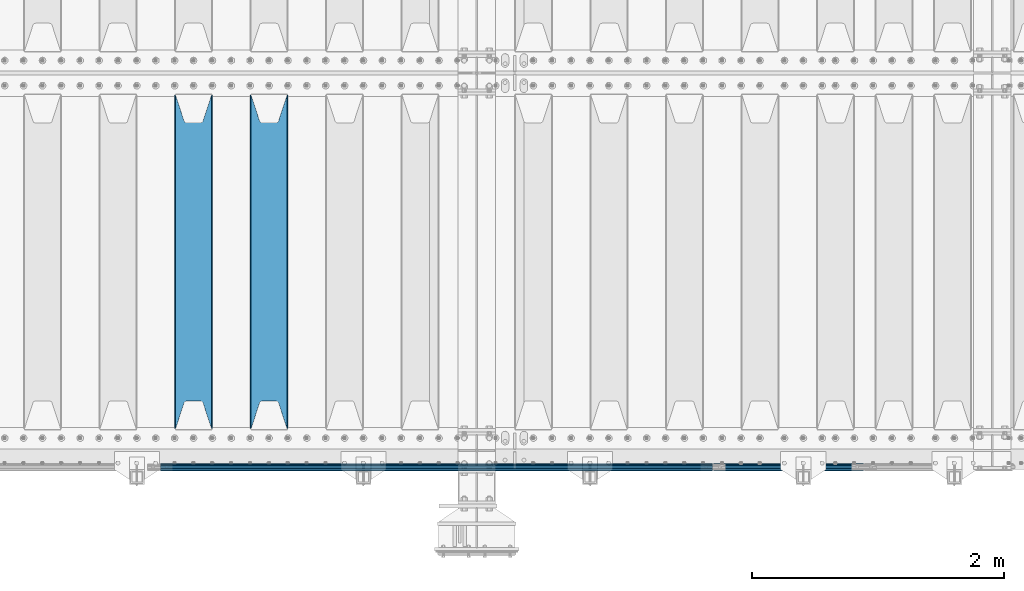
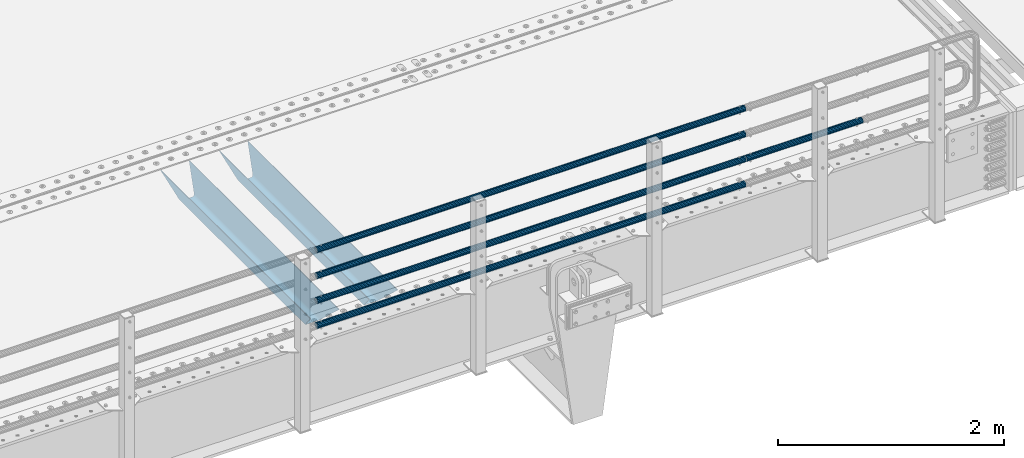
# One storey, part 114 of 247: 7 beams.
"""IFC2X3 building model written with IfcOpenShell, lengths in millimetres."""

from ifc_helpers import new_model, si_unit, frame, origin_with_axes, place, context, subcontext, project, spatial, faceted_brep, material, type_object, element, save


model = new_model("IFC2X3")

# Units and contexts
model_context = context("Model", 3, precision=1e-05, world=origin_with_axes())
body_context = subcontext(model_context, "Body", "Model", "MODEL_VIEW")
ifc_project = project(units=[si_unit("LENGTHUNIT", "METRE", prefix="MILLI"), si_unit("AREAUNIT", "SQUARE_METRE"), si_unit("VOLUMEUNIT", "CUBIC_METRE"), si_unit("MASSUNIT", "GRAM", prefix="KILO"), si_unit("TIMEUNIT", "SECOND"), si_unit("PLANEANGLEUNIT", "RADIAN"), si_unit("SOLIDANGLEUNIT", "STERADIAN"), si_unit("THERMODYNAMICTEMPERATUREUNIT", "DEGREE_CELSIUS"), si_unit("LUMINOUSINTENSITYUNIT", "LUMEN")], contexts=[model_context])

# Site, building, storey
site_placement = place(None, origin_with_axes())
site = spatial("IfcSite", under=ifc_project, at=site_placement, CompositionType="ELEMENT")
building_placement = place(site_placement, origin_with_axes())
building = spatial("IfcBuilding", under=site, at=building_placement, Name="Standard", CompositionType="ELEMENT")
storey_placement = place(building_placement, origin_with_axes())
storey = spatial("IfcBuildingStorey", under=building, at=storey_placement, Name="Undefined", CompositionType="ELEMENT", Elevation=0.0)

# Beams
ifc_material_1 = material(Name="STEEL/S355N")
beam_type_1 = type_object("IfcBeamType", PredefinedType="NOTDEFINED")
beam_1_placement = place(storey_placement, frame((10600.0, 175.0, -115.0), z_axis=(0.0, 0.0, 1.0), x_axis=(0.0, 1.0, 0.0)))
element("IfcBeam", 1, at=beam_1_placement, inside=storey, type_object=beam_type_1, material=ifc_material_1, context=body_context, shape_type="Brep", body=[
    faceted_brep([(0.0, 150.0, 115.0), (0.0, 143.689999999999, 115.0), (2650.00000000297, 143.689999999999, 115.0), (2650.00000000297, 150.0, 115.0), (2650.00000000297, 142.059565218402, 110.0000000031), (2650.00000000297, 148.369565218403, 110.0000000031), (2441.90079219208, -80.1103600731112, -98.0992078077845), (2437.7588105432, -77.5672621345584, -102.241189456673), (2434.06523489746, -74.4080125315522, -105.934765102404), (2430.91086095089, -70.710272125576, -109.089139048974), (2428.37322971128, -66.5649389910068, -111.626770288588), (2426.51472138054, -62.0739139532889, -113.485278619323), (2425.38102192091, -57.3475956567672, -114.618978078955), (2424.99999999987, -52.5021667386536, -115.0), (2424.99999999987, 52.5021667386536, -115.0), (2425.38102192091, 57.3475956567672, -114.618978078955), (2426.51472138054, 62.0739139532889, -113.485278619323), (2428.37322971128, 66.5649389910068, -111.626770288588), (2430.91086095089, 70.710272125576, -109.089139048974), (2434.06523489746, 74.4080125315522, -105.934765102404), (2437.7588105432, 77.5672621345584, -102.241189456673), (2441.90079219208, 80.1103600731112, -98.0992078077846), (2446.38936140511, 81.9747917625791, -93.6106385947584), (2448.24948500409, 76.2713538057251, -91.7505149957729), (2444.62967112262, 74.76777986261, -95.3703288772456), (2441.28936334126, 72.7168944282894, -98.710636658607), (2438.31067330438, 70.1691124903846, -101.689326695487), (2435.76682334747, 67.1870637758839, -104.233176652398), (2433.72034654133, 63.8440531834895, -106.279653458539), (2432.22154950041, 60.222258798236, -107.778450499454), (2431.30727574265, 56.4107117849089, -108.692724257221), (2430.99999999987, 52.5031078186876, -109.0), (2430.99999999987, -52.5031078186876, -109.0), (2431.30727574265, -56.4107117849089, -108.692724257221), (2432.22154950041, -60.222258798236, -107.778450499454), (2433.72034654133, -63.8440531834895, -106.279653458539), (2435.76682334747, -67.1870637758839, -104.233176652398), (2438.31067330438, -70.1691124903846, -101.689326695487), (2441.28936334126, -72.7168944282894, -98.7106366586071), (2444.62967112262, -74.76777986261, -95.3703288772457), (2448.24948500409, -76.2713538057251, -91.7505149957729), (2650.00000000297, -142.059565218402, 110.0000000031), (2650.00000000297, -148.369565218403, 110.0000000031), (2446.38936140511, -81.9747917625791, -93.6106385947584), (2650.00000000297, -143.689999999999, 115.0), (2650.00000000297, -150.0, 115.0), (0.0, -143.689999999999, 115.0), (0.0, -150.0, 115.0), (0.0, -148.369565218261, 110.000000002663), (203.610638597422, -81.9747917625791, -93.6106385947584), (208.099207810448, -80.1103600731112, -98.0992078077845), (212.241189459336, -77.5672621345584, -102.241189456673), (215.934765105068, -74.4080125315522, -105.934765102404), (219.089139051637, -70.710272125576, -109.089139048974), (221.626770291251, -66.5649389910068, -111.626770288588), (223.485278621985, -62.0739139532889, -113.485278619323), (224.618978081617, -57.3475956567672, -114.618978078955), (225.000000002663, -52.5021667386536, -115.0), (225.000000002663, 52.5021667386536, -115.0), (224.618978081617, 57.3475956567672, -114.618978078955), (223.485278621985, 62.0739139532889, -113.485278619323), (221.626770291251, 66.5649389910068, -111.626770288588), (219.089139051637, 70.710272125576, -109.089139048974), (215.934765105068, 74.4080125315522, -105.934765102404), (212.241189459336, 77.5672621345584, -102.241189456673), (208.099207810448, 80.1103600731112, -98.0992078077846), (203.610638597422, 81.9747917625791, -93.6106385947584), (0.0, 148.369565218261, 110.000000002663), (0.0, 142.05956521826, 110.000000002663), (201.750514998436, 76.2713538057251, -91.7505149957729), (205.370328879908, 74.76777986261, -95.3703288772456), (208.710636661271, 72.7168944282894, -98.710636658607), (211.68932669815, 70.1691124903846, -101.689326695487), (214.233176655061, 67.1870637758839, -104.233176652398), (216.279653461202, 63.8440531834895, -106.279653458539), (217.778450502117, 60.222258798236, -107.778450499454), (218.692724259885, 56.4107117849089, -108.692724257221), (219.000000002663, 52.5031078186876, -109.0), (219.000000002663, -52.5031078186876, -109.0), (218.692724259885, -56.4107117849089, -108.692724257221), (217.778450502117, -60.222258798236, -107.778450499454), (216.279653461202, -63.8440531834895, -106.279653458539), (214.233176655061, -67.1870637758839, -104.233176652398), (211.68932669815, -70.1691124903846, -101.689326695487), (208.710636661271, -72.7168944282894, -98.7106366586071), (205.370328879908, -74.76777986261, -95.3703288772457), (201.750514998436, -76.2713538057251, -91.7505149957729), (0.0, -142.05956521826, 110.000000002663)], [[[0, 1, 2, 3]], [[3, 2, 4, 5]], [[6, 7, 8, 9, 10, 11, 12, 13, 14, 15, 16, 17, 18, 19, 20, 21, 22, 5, 4, 23, 24, 25, 26, 27, 28, 29, 30, 31, 32, 33, 34, 35, 36, 37, 38, 39, 40, 41, 42, 43]], [[44, 45, 42, 41]], [[46, 47, 45, 44]], [[43, 42, 45, 47, 48, 49]], [[6, 43, 49, 50]], [[7, 6, 50, 51]], [[8, 7, 51, 52]], [[9, 8, 52, 53]], [[10, 9, 53, 54]], [[11, 10, 54, 55]], [[12, 11, 55, 56]], [[13, 12, 56, 57]], [[14, 13, 57, 58]], [[15, 14, 58, 59]], [[16, 15, 59, 60]], [[17, 16, 60, 61]], [[18, 17, 61, 62]], [[19, 18, 62, 63]], [[20, 19, 63, 64]], [[21, 20, 64, 65]], [[22, 21, 65, 66]], [[0, 3, 5, 22, 66, 67]], [[1, 0, 67, 68]], [[23, 4, 2, 1, 68, 69]], [[24, 23, 69, 70]], [[25, 24, 70, 71]], [[26, 25, 71, 72]], [[27, 26, 72, 73]], [[28, 27, 73, 74]], [[29, 28, 74, 75]], [[30, 29, 75, 76]], [[31, 30, 76, 77]], [[32, 31, 77, 78]], [[33, 32, 78, 79]], [[34, 33, 79, 80]], [[35, 34, 80, 81]], [[36, 35, 81, 82]], [[37, 36, 82, 83]], [[38, 37, 83, 84]], [[39, 38, 84, 85]], [[40, 39, 85, 86]], [[46, 44, 41, 40, 86, 87]], [[47, 46, 87, 48]], [[86, 85, 84, 83, 82, 81, 80, 79, 78, 77, 76, 75, 74, 73, 72, 71, 70, 69, 68, 67, 66, 65, 64, 63, 62, 61, 60, 59, 58, 57, 56, 55, 54, 53, 52, 51, 50, 49, 48, 87]]]),
])
beam_2_placement = place(storey_placement, frame((10000.0, 175.0, -115.0), z_axis=(0.0, 0.0, 1.0), x_axis=(0.0, 1.0, 0.0)))
element("IfcBeam", 2, at=beam_2_placement, inside=storey, type_object=beam_type_1, material=ifc_material_1, context=body_context, shape_type="Brep", body=[
    faceted_brep([(0.0, 150.0, 115.0), (0.0, 143.689999999999, 115.0), (2650.00000000297, 143.689999999999, 115.0), (2650.00000000297, 150.0, 115.0), (2650.00000000297, 142.059565218402, 110.0000000031), (2650.00000000297, 148.369565218403, 110.0000000031), (2441.90079219208, -80.1103600731112, -98.0992078077845), (2437.7588105432, -77.5672621345584, -102.241189456673), (2434.06523489746, -74.4080125315522, -105.934765102404), (2430.91086095089, -70.710272125576, -109.089139048974), (2428.37322971128, -66.5649389910068, -111.626770288588), (2426.51472138054, -62.0739139532889, -113.485278619323), (2425.38102192091, -57.3475956567672, -114.618978078955), (2424.99999999987, -52.5021667386536, -115.0), (2424.99999999987, 52.5021667386536, -115.0), (2425.38102192091, 57.3475956567672, -114.618978078955), (2426.51472138054, 62.0739139532889, -113.485278619323), (2428.37322971128, 66.5649389910068, -111.626770288588), (2430.91086095089, 70.710272125576, -109.089139048974), (2434.06523489746, 74.4080125315522, -105.934765102404), (2437.7588105432, 77.5672621345584, -102.241189456673), (2441.90079219208, 80.1103600731112, -98.0992078077846), (2446.38936140511, 81.9747917625791, -93.6106385947584), (2448.24948500409, 76.2713538057251, -91.7505149957729), (2444.62967112262, 74.76777986261, -95.3703288772456), (2441.28936334126, 72.7168944282894, -98.710636658607), (2438.31067330438, 70.1691124903846, -101.689326695487), (2435.76682334747, 67.1870637758839, -104.233176652398), (2433.72034654133, 63.8440531834895, -106.279653458539), (2432.22154950041, 60.222258798236, -107.778450499454), (2431.30727574265, 56.4107117849089, -108.692724257221), (2430.99999999987, 52.5031078186876, -109.0), (2430.99999999987, -52.5031078186876, -109.0), (2431.30727574265, -56.4107117849089, -108.692724257221), (2432.22154950041, -60.222258798236, -107.778450499454), (2433.72034654133, -63.8440531834895, -106.279653458539), (2435.76682334747, -67.1870637758839, -104.233176652398), (2438.31067330438, -70.1691124903846, -101.689326695487), (2441.28936334126, -72.7168944282894, -98.7106366586071), (2444.62967112262, -74.76777986261, -95.3703288772457), (2448.24948500409, -76.2713538057251, -91.7505149957729), (2650.00000000297, -142.059565218402, 110.0000000031), (2650.00000000297, -148.369565218403, 110.0000000031), (2446.38936140511, -81.9747917625791, -93.6106385947584), (2650.00000000297, -143.689999999999, 115.0), (2650.00000000297, -150.0, 115.0), (0.0, -143.689999999999, 115.0), (0.0, -150.0, 115.0), (0.0, -148.369565218261, 110.000000002663), (203.610638597422, -81.9747917625791, -93.6106385947584), (208.099207810448, -80.1103600731112, -98.0992078077845), (212.241189459336, -77.5672621345584, -102.241189456673), (215.934765105068, -74.4080125315522, -105.934765102404), (219.089139051637, -70.710272125576, -109.089139048974), (221.626770291251, -66.5649389910068, -111.626770288588), (223.485278621985, -62.0739139532889, -113.485278619323), (224.618978081617, -57.3475956567672, -114.618978078955), (225.000000002663, -52.5021667386536, -115.0), (225.000000002663, 52.5021667386536, -115.0), (224.618978081617, 57.3475956567672, -114.618978078955), (223.485278621985, 62.0739139532889, -113.485278619323), (221.626770291251, 66.5649389910068, -111.626770288588), (219.089139051637, 70.710272125576, -109.089139048974), (215.934765105068, 74.4080125315522, -105.934765102404), (212.241189459336, 77.5672621345584, -102.241189456673), (208.099207810448, 80.1103600731112, -98.0992078077846), (203.610638597422, 81.9747917625791, -93.6106385947584), (0.0, 148.369565218261, 110.000000002663), (0.0, 142.05956521826, 110.000000002663), (201.750514998436, 76.2713538057251, -91.7505149957729), (205.370328879908, 74.76777986261, -95.3703288772456), (208.710636661271, 72.7168944282894, -98.710636658607), (211.68932669815, 70.1691124903846, -101.689326695487), (214.233176655061, 67.1870637758839, -104.233176652398), (216.279653461202, 63.8440531834895, -106.279653458539), (217.778450502117, 60.222258798236, -107.778450499454), (218.692724259885, 56.4107117849089, -108.692724257221), (219.000000002663, 52.5031078186876, -109.0), (219.000000002663, -52.5031078186876, -109.0), (218.692724259885, -56.4107117849089, -108.692724257221), (217.778450502117, -60.222258798236, -107.778450499454), (216.279653461202, -63.8440531834895, -106.279653458539), (214.233176655061, -67.1870637758839, -104.233176652398), (211.68932669815, -70.1691124903846, -101.689326695487), (208.710636661271, -72.7168944282894, -98.7106366586071), (205.370328879908, -74.76777986261, -95.3703288772457), (201.750514998436, -76.2713538057251, -91.7505149957729), (0.0, -142.05956521826, 110.000000002663)], [[[0, 1, 2, 3]], [[3, 2, 4, 5]], [[6, 7, 8, 9, 10, 11, 12, 13, 14, 15, 16, 17, 18, 19, 20, 21, 22, 5, 4, 23, 24, 25, 26, 27, 28, 29, 30, 31, 32, 33, 34, 35, 36, 37, 38, 39, 40, 41, 42, 43]], [[44, 45, 42, 41]], [[46, 47, 45, 44]], [[43, 42, 45, 47, 48, 49]], [[6, 43, 49, 50]], [[7, 6, 50, 51]], [[8, 7, 51, 52]], [[9, 8, 52, 53]], [[10, 9, 53, 54]], [[11, 10, 54, 55]], [[12, 11, 55, 56]], [[13, 12, 56, 57]], [[14, 13, 57, 58]], [[15, 14, 58, 59]], [[16, 15, 59, 60]], [[17, 16, 60, 61]], [[18, 17, 61, 62]], [[19, 18, 62, 63]], [[20, 19, 63, 64]], [[21, 20, 64, 65]], [[22, 21, 65, 66]], [[0, 3, 5, 22, 66, 67]], [[1, 0, 67, 68]], [[23, 4, 2, 1, 68, 69]], [[24, 23, 69, 70]], [[25, 24, 70, 71]], [[26, 25, 71, 72]], [[27, 26, 72, 73]], [[28, 27, 73, 74]], [[29, 28, 74, 75]], [[30, 29, 75, 76]], [[31, 30, 76, 77]], [[32, 31, 77, 78]], [[33, 32, 78, 79]], [[34, 33, 79, 80]], [[35, 34, 80, 81]], [[36, 35, 81, 82]], [[37, 36, 82, 83]], [[38, 37, 83, 84]], [[39, 38, 84, 85]], [[40, 39, 85, 86]], [[46, 44, 41, 40, 86, 87]], [[47, 46, 87, 48]], [[86, 85, 84, 83, 82, 81, 80, 79, 78, 77, 76, 75, 74, 73, 72, 71, 70, 69, 68, 67, 66, 65, 64, 63, 62, 61, 60, 59, 58, 57, 56, 55, 54, 53, 52, 51, 50, 49, 48, 87]]]),
])
ifc_material_2 = material()
beam_type_2 = type_object("IfcBeamType", PredefinedType="NOTDEFINED")
beam_3_placement = place(storey_placement, frame((14121.9999999999, -129.849999999805, 149.849999999725), z_axis=(0.0, 0.0, -1.0), x_axis=(-1.0, 0.0, 0.0)))
element("IfcBeam", 3, at=beam_3_placement, inside=storey, type_object=beam_type_2, material=ifc_material_2, context=body_context, shape_type="Brep", body=[
    faceted_brep([(0.0, -26.5499999999993, 0.0), (0.0, -24.5290015881747, 10.1602451292931), (4384.0, -24.5290015881747, 10.1602451292931), (4384.0, -26.5499999999993, 0.0), (0.0, -18.7736850405036, 18.7736850405028), (4384.0, -18.7736850405036, 18.7736850405028), (0.0, -10.1602451292929, 24.5290015881747), (4384.0, -10.1602451292929, 24.5290015881747), (0.0, 0.0, 26.55), (4384.0, 0.0, 26.55), (0.0, 10.1602451292929, 24.5290015881747), (4384.0, 10.1602451292929, 24.5290015881747), (0.0, 18.7736850405036, 18.7736850405028), (4384.0, 18.7736850405036, 18.7736850405028), (0.0, 24.5290015881747, 10.1602451292931), (4384.0, 24.5290015881747, 10.1602451292931), (0.0, 26.5499999999993, 0.0), (4384.0, 26.5499999999993, 0.0), (0.0, 24.5290015881747, -10.1602451292931), (4384.0, 24.5290015881747, -10.1602451292931), (0.0, 18.7736850405036, -18.7736850405028), (4384.0, 18.7736850405036, -18.7736850405028), (0.0, 10.1602451292929, -24.5290015881747), (4384.0, 10.1602451292929, -24.5290015881747), (0.0, 0.0, -26.55), (4384.0, 0.0, -26.55), (0.0, -10.1602451292929, -24.5290015881747), (4384.0, -10.1602451292929, -24.5290015881747), (0.0, -18.7736850405036, -18.7736850405028), (4384.0, -18.7736850405036, -18.7736850405028), (0.0, -24.5290015881747, -10.1602451292931), (4384.0, -24.5290015881747, -10.1602451292931), (0.0, -30.1499999999996, 0.0), (0.0, -27.8549679052148, -11.5379054858076), (4384.0, -27.8549679052157, -11.5379054858075), (4384.0, -30.1499999999996, 0.0), (0.0, -21.3192694527743, -21.3192694527752), (4384.0, -21.3192694527752, -21.3192694527744), (0.0, -11.5379054858076, -27.8549679052157), (4384.0, -11.5379054858076, -27.8549679052153), (0.0, 0.0, -30.1499999999996), (4384.0, 0.0, -30.15), (0.0, 11.5379054858076, -27.8549679052157), (4384.0, 11.5379054858076, -27.8549679052153), (0.0, 21.3192694527743, -21.3192694527752), (4384.0, 21.3192694527752, -21.3192694527744), (0.0, 27.8549679052157, -11.5379054858076), (4384.0, 27.8549679052157, -11.5379054858074), (0.0, 30.1499999999996, 0.0), (4384.0, 30.1499999999996, 0.0), (0.0, 27.8549679052157, 11.5379054858076), (4384.0, 27.8549679052157, 11.5379054858075), (0.0, 21.3192694527743, 21.3192694527752), (4384.0, 21.3192694527752, 21.3192694527744), (0.0, 11.5379054858076, 27.8549679052157), (4384.0, 11.5379054858076, 27.8549679052153), (0.0, 0.0, 30.1499999999996), (4384.0, 0.0, 30.15), (0.0, -11.5379054858076, 27.8549679052157), (4384.0, -11.5379054858076, 27.8549679052153), (0.0, -21.3192694527743, 21.3192694527752), (4384.0, -21.3192694527752, 21.3192694527744), (0.0, -27.8549679052157, 11.5379054858076), (4384.0, -27.8549679052157, 11.5379054858075)], [[[0, 1, 2, 3]], [[1, 4, 5, 2]], [[4, 6, 7, 5]], [[6, 8, 9, 7]], [[8, 10, 11, 9]], [[10, 12, 13, 11]], [[12, 14, 15, 13]], [[14, 16, 17, 15]], [[16, 18, 19, 17]], [[18, 20, 21, 19]], [[20, 22, 23, 21]], [[22, 24, 25, 23]], [[24, 26, 27, 25]], [[26, 28, 29, 27]], [[28, 30, 31, 29]], [[30, 0, 3, 31]], [[32, 33, 34, 35]], [[33, 36, 37, 34]], [[36, 38, 39, 37]], [[38, 40, 41, 39]], [[40, 42, 43, 41]], [[42, 44, 45, 43]], [[44, 46, 47, 45]], [[46, 48, 49, 47]], [[48, 50, 51, 49]], [[50, 52, 53, 51]], [[52, 54, 55, 53]], [[54, 56, 57, 55]], [[56, 58, 59, 57]], [[58, 60, 61, 59]], [[60, 62, 63, 61]], [[62, 32, 35, 63]], [[37, 39, 41, 43, 45, 47, 49, 51, 53, 55, 57, 59, 61, 63, 35, 34], [5, 7, 9, 11, 13, 15, 17, 19, 21, 23, 25, 27, 29, 31, 3, 2]], [[62, 60, 58, 56, 54, 52, 50, 48, 46, 44, 42, 40, 38, 36, 33, 32], [30, 28, 26, 24, 22, 20, 18, 16, 14, 12, 10, 8, 6, 4, 1, 0]]]),
])
beam_4_placement = place(storey_placement, frame((14121.9999999999, -129.849999999805, 420.149999999728), z_axis=(0.0, 0.0, -1.0), x_axis=(-1.0, 0.0, 0.0)))
element("IfcBeam", 4, at=beam_4_placement, inside=storey, type_object=beam_type_2, material=ifc_material_2, context=body_context, shape_type="Brep", body=[
    faceted_brep([(0.0, -26.5499999999993, 0.0), (0.0, -24.5290015881747, 10.1602451292931), (4384.0, -24.5290015881747, 10.1602451292931), (4384.0, -26.5499999999993, 0.0), (0.0, -18.7736850405036, 18.7736850405028), (4384.0, -18.7736850405036, 18.7736850405028), (0.0, -10.1602451292929, 24.5290015881747), (4384.0, -10.1602451292929, 24.5290015881747), (0.0, 0.0, 26.55), (4384.0, 0.0, 26.55), (0.0, 10.1602451292929, 24.5290015881747), (4384.0, 10.1602451292929, 24.5290015881747), (0.0, 18.7736850405036, 18.7736850405028), (4384.0, 18.7736850405036, 18.7736850405028), (0.0, 24.5290015881747, 10.1602451292931), (4384.0, 24.5290015881747, 10.1602451292931), (0.0, 26.5499999999993, 0.0), (4384.0, 26.5499999999993, 0.0), (0.0, 24.5290015881747, -10.1602451292931), (4384.0, 24.5290015881747, -10.1602451292931), (0.0, 18.7736850405036, -18.7736850405028), (4384.0, 18.7736850405036, -18.7736850405028), (0.0, 10.1602451292929, -24.5290015881747), (4384.0, 10.1602451292929, -24.5290015881747), (0.0, 0.0, -26.55), (4384.0, 0.0, -26.55), (0.0, -10.1602451292929, -24.5290015881747), (4384.0, -10.1602451292929, -24.5290015881747), (0.0, -18.7736850405036, -18.7736850405028), (4384.0, -18.7736850405036, -18.7736850405028), (0.0, -24.5290015881747, -10.1602451292931), (4384.0, -24.5290015881747, -10.1602451292931), (0.0, -30.1499999999996, 0.0), (0.0, -27.8549679052148, -11.5379054858076), (4384.0, -27.8549679052157, -11.5379054858075), (4384.0, -30.1499999999996, 0.0), (0.0, -21.3192694527743, -21.3192694527752), (4384.0, -21.3192694527752, -21.3192694527744), (0.0, -11.5379054858076, -27.8549679052157), (4384.0, -11.5379054858076, -27.8549679052153), (0.0, 0.0, -30.1499999999996), (4384.0, 0.0, -30.15), (0.0, 11.5379054858076, -27.8549679052157), (4384.0, 11.5379054858076, -27.8549679052153), (0.0, 21.3192694527743, -21.3192694527752), (4384.0, 21.3192694527752, -21.3192694527744), (0.0, 27.8549679052157, -11.5379054858076), (4384.0, 27.8549679052157, -11.5379054858074), (0.0, 30.1499999999996, 0.0), (4384.0, 30.1499999999996, 0.0), (0.0, 27.8549679052157, 11.5379054858076), (4384.0, 27.8549679052157, 11.5379054858075), (0.0, 21.3192694527743, 21.3192694527752), (4384.0, 21.3192694527752, 21.3192694527744), (0.0, 11.5379054858076, 27.8549679052157), (4384.0, 11.5379054858076, 27.8549679052153), (0.0, 0.0, 30.1499999999996), (4384.0, 0.0, 30.15), (0.0, -11.5379054858076, 27.8549679052157), (4384.0, -11.5379054858076, 27.8549679052153), (0.0, -21.3192694527743, 21.3192694527752), (4384.0, -21.3192694527752, 21.3192694527744), (0.0, -27.8549679052157, 11.5379054858076), (4384.0, -27.8549679052157, 11.5379054858075)], [[[0, 1, 2, 3]], [[1, 4, 5, 2]], [[4, 6, 7, 5]], [[6, 8, 9, 7]], [[8, 10, 11, 9]], [[10, 12, 13, 11]], [[12, 14, 15, 13]], [[14, 16, 17, 15]], [[16, 18, 19, 17]], [[18, 20, 21, 19]], [[20, 22, 23, 21]], [[22, 24, 25, 23]], [[24, 26, 27, 25]], [[26, 28, 29, 27]], [[28, 30, 31, 29]], [[30, 0, 3, 31]], [[32, 33, 34, 35]], [[33, 36, 37, 34]], [[36, 38, 39, 37]], [[38, 40, 41, 39]], [[40, 42, 43, 41]], [[42, 44, 45, 43]], [[44, 46, 47, 45]], [[46, 48, 49, 47]], [[48, 50, 51, 49]], [[50, 52, 53, 51]], [[52, 54, 55, 53]], [[54, 56, 57, 55]], [[56, 58, 59, 57]], [[58, 60, 61, 59]], [[60, 62, 63, 61]], [[62, 32, 35, 63]], [[37, 39, 41, 43, 45, 47, 49, 51, 53, 55, 57, 59, 61, 63, 35, 34], [5, 7, 9, 11, 13, 15, 17, 19, 21, 23, 25, 27, 29, 31, 3, 2]], [[62, 60, 58, 56, 54, 52, 50, 48, 46, 44, 42, 40, 38, 36, 33, 32], [30, 28, 26, 24, 22, 20, 18, 16, 14, 12, 10, 8, 6, 4, 1, 0]]]),
])
beam_5_placement = place(storey_placement, frame((14121.9999999999, -129.849999999805, 969.849999999725), z_axis=(0.0, 0.0, -1.0), x_axis=(-1.0, 0.0, 0.0)))
element("IfcBeam", 5, at=beam_5_placement, inside=storey, type_object=beam_type_2, material=ifc_material_2, context=body_context, shape_type="Brep", body=[
    faceted_brep([(0.0, -26.5499999999993, 0.0), (0.0, -24.5290015881747, 10.1602451292931), (4384.0, -24.5290015881747, 10.1602451292931), (4384.0, -26.5499999999993, 0.0), (0.0, -18.7736850405036, 18.7736850405028), (4384.0, -18.7736850405036, 18.7736850405028), (0.0, -10.1602451292929, 24.5290015881747), (4384.0, -10.1602451292929, 24.5290015881747), (0.0, 0.0, 26.55), (4384.0, 0.0, 26.55), (0.0, 10.1602451292929, 24.5290015881747), (4384.0, 10.1602451292929, 24.5290015881747), (0.0, 18.7736850405036, 18.7736850405028), (4384.0, 18.7736850405036, 18.7736850405028), (0.0, 24.5290015881747, 10.1602451292931), (4384.0, 24.5290015881747, 10.1602451292931), (0.0, 26.5499999999993, 0.0), (4384.0, 26.5499999999993, 0.0), (0.0, 24.5290015881747, -10.1602451292931), (4384.0, 24.5290015881747, -10.1602451292931), (0.0, 18.7736850405036, -18.7736850405028), (4384.0, 18.7736850405036, -18.7736850405028), (0.0, 10.1602451292929, -24.5290015881747), (4384.0, 10.1602451292929, -24.5290015881747), (0.0, 0.0, -26.55), (4384.0, 0.0, -26.55), (0.0, -10.1602451292929, -24.5290015881747), (4384.0, -10.1602451292929, -24.5290015881747), (0.0, -18.7736850405036, -18.7736850405028), (4384.0, -18.7736850405036, -18.7736850405028), (0.0, -24.5290015881747, -10.1602451292931), (4384.0, -24.5290015881747, -10.1602451292931), (0.0, -30.1499999999996, 0.0), (0.0, -27.8549679052148, -11.5379054858076), (4384.0, -27.8549679052157, -11.5379054858075), (4384.0, -30.1499999999996, 0.0), (0.0, -21.3192694527743, -21.3192694527752), (4384.0, -21.3192694527752, -21.3192694527744), (0.0, -11.5379054858076, -27.8549679052157), (4384.0, -11.5379054858076, -27.8549679052153), (0.0, 0.0, -30.1499999999996), (4384.0, 0.0, -30.15), (0.0, 11.5379054858076, -27.8549679052157), (4384.0, 11.5379054858076, -27.8549679052153), (0.0, 21.3192694527743, -21.3192694527752), (4384.0, 21.3192694527752, -21.3192694527744), (0.0, 27.8549679052157, -11.5379054858076), (4384.0, 27.8549679052157, -11.5379054858074), (0.0, 30.1499999999996, 0.0), (4384.0, 30.1499999999996, 0.0), (0.0, 27.8549679052157, 11.5379054858076), (4384.0, 27.8549679052157, 11.5379054858075), (0.0, 21.3192694527743, 21.3192694527752), (4384.0, 21.3192694527752, 21.3192694527744), (0.0, 11.5379054858076, 27.8549679052157), (4384.0, 11.5379054858076, 27.8549679052153), (0.0, 0.0, 30.1499999999996), (4384.0, 0.0, 30.15), (0.0, -11.5379054858076, 27.8549679052157), (4384.0, -11.5379054858076, 27.8549679052153), (0.0, -21.3192694527743, 21.3192694527752), (4384.0, -21.3192694527752, 21.3192694527744), (0.0, -27.8549679052157, 11.5379054858076), (4384.0, -27.8549679052157, 11.5379054858075)], [[[0, 1, 2, 3]], [[1, 4, 5, 2]], [[4, 6, 7, 5]], [[6, 8, 9, 7]], [[8, 10, 11, 9]], [[10, 12, 13, 11]], [[12, 14, 15, 13]], [[14, 16, 17, 15]], [[16, 18, 19, 17]], [[18, 20, 21, 19]], [[20, 22, 23, 21]], [[22, 24, 25, 23]], [[24, 26, 27, 25]], [[26, 28, 29, 27]], [[28, 30, 31, 29]], [[30, 0, 3, 31]], [[32, 33, 34, 35]], [[33, 36, 37, 34]], [[36, 38, 39, 37]], [[38, 40, 41, 39]], [[40, 42, 43, 41]], [[42, 44, 45, 43]], [[44, 46, 47, 45]], [[46, 48, 49, 47]], [[48, 50, 51, 49]], [[50, 52, 53, 51]], [[52, 54, 55, 53]], [[54, 56, 57, 55]], [[56, 58, 59, 57]], [[58, 60, 61, 59]], [[60, 62, 63, 61]], [[62, 32, 35, 63]], [[37, 39, 41, 43, 45, 47, 49, 51, 53, 55, 57, 59, 61, 63, 35, 34], [5, 7, 9, 11, 13, 15, 17, 19, 21, 23, 25, 27, 29, 31, 3, 2]], [[62, 60, 58, 56, 54, 52, 50, 48, 46, 44, 42, 40, 38, 36, 33, 32], [30, 28, 26, 24, 22, 20, 18, 16, 14, 12, 10, 8, 6, 4, 1, 0]]]),
])
beam_6_placement = place(storey_placement, frame((14132.0000000001, -129.850000000402, 419.849999999725), z_axis=(0.0, -0.999999999999548, -9.5100000000016e-07), x_axis=(1.0, 0.0, 0.0)))
element("IfcBeam", 6, at=beam_6_placement, inside=storey, type_object=beam_type_2, material=ifc_material_2, context=body_context, shape_type="Brep", body=[
    faceted_brep([(0.0, -26.5499999999993, 0.0), (0.0, -24.5290015881747, 10.1602451292931), (1190.0, -24.5290015881747, 10.1602451292929), (1190.0, -26.55, 0.0), (0.0, -18.7736850405036, 18.7736850405028), (1190.0, -18.7736850405028, 18.7736850405036), (0.0, -10.1602451292929, 24.5290015881747), (1190.0, -10.1602451292931, 24.5290015881747), (0.0, 0.0, 26.55), (1190.0, 0.0, 26.5499999999993), (0.0, 10.1602451292929, 24.5290015881747), (1190.0, 10.1602451292932, 24.5290015881747), (0.0, 18.7736850405036, 18.7736850405028), (1190.0, 18.7736850405029, 18.7736850405036), (0.0, 24.5290015881747, 10.1602451292931), (1190.0, 24.5290015881747, 10.1602451292929), (0.0, 26.5499999999993, 0.0), (1190.0, 26.55, 0.0), (0.0, 24.5290015881747, -10.1602451292931), (1190.0, 24.5290015881747, -10.1602451292929), (0.0, 18.7736850405036, -18.7736850405028), (1190.0, 18.7736850405028, -18.7736850405036), (0.0, 10.1602451292929, -24.5290015881747), (1190.0, 10.1602451292931, -24.5290015881747), (0.0, 0.0, -26.55), (1190.0, 0.0, -26.5499999999993), (0.0, -10.1602451292929, -24.5290015881747), (1190.0, -10.1602451292931, -24.5290015881747), (0.0, -18.7736850405036, -18.7736850405028), (1190.0, -18.7736850405028, -18.7736850405036), (0.0, -24.5290015881747, -10.1602451292931), (1190.0, -24.5290015881747, -10.1602451292929), (0.0, -30.1499999999996, 0.0), (0.0, -27.8549679052148, -11.5379054858076), (1190.0, -27.8549679052153, -11.5379054858076), (1190.0, -30.15, 0.0), (0.0, -21.3192694527743, -21.3192694527752), (1190.0, -21.3192694527744, -21.3192694527752), (0.0, -11.5379054858076, -27.8549679052157), (1190.0, -11.5379054858075, -27.8549679052157), (0.0, 0.0, -30.1499999999996), (1190.0, 0.0, -30.1499999999996), (0.0, 11.5379054858076, -27.8549679052157), (1190.0, 11.5379054858075, -27.8549679052157), (0.0, 21.3192694527743, -21.3192694527752), (1190.0, 21.3192694527744, -21.3192694527752), (0.0, 27.8549679052157, -11.5379054858076), (1190.0, 27.8549679052153, -11.5379054858076), (0.0, 30.1499999999996, 0.0), (1190.0, 30.15, 0.0), (0.0, 27.8549679052157, 11.5379054858076), (1190.0, 27.8549679052153, 11.5379054858076), (0.0, 21.3192694527743, 21.3192694527752), (1190.0, 21.3192694527744, 21.3192694527752), (0.0, 11.5379054858076, 27.8549679052157), (1190.0, 11.5379054858075, 27.8549679052157), (0.0, 0.0, 30.1499999999996), (1190.0, 0.0, 30.1499999999996), (0.0, -11.5379054858076, 27.8549679052157), (1190.0, -11.5379054858075, 27.8549679052157), (0.0, -21.3192694527743, 21.3192694527752), (1190.0, -21.3192694527744, 21.3192694527752), (0.0, -27.8549679052157, 11.5379054858076), (1190.0, -27.8549679052153, 11.5379054858076)], [[[0, 1, 2, 3]], [[1, 4, 5, 2]], [[4, 6, 7, 5]], [[6, 8, 9, 7]], [[8, 10, 11, 9]], [[10, 12, 13, 11]], [[12, 14, 15, 13]], [[14, 16, 17, 15]], [[16, 18, 19, 17]], [[18, 20, 21, 19]], [[20, 22, 23, 21]], [[22, 24, 25, 23]], [[24, 26, 27, 25]], [[26, 28, 29, 27]], [[28, 30, 31, 29]], [[30, 0, 3, 31]], [[32, 33, 34, 35]], [[33, 36, 37, 34]], [[36, 38, 39, 37]], [[38, 40, 41, 39]], [[40, 42, 43, 41]], [[42, 44, 45, 43]], [[44, 46, 47, 45]], [[46, 48, 49, 47]], [[48, 50, 51, 49]], [[50, 52, 53, 51]], [[52, 54, 55, 53]], [[54, 56, 57, 55]], [[56, 58, 59, 57]], [[58, 60, 61, 59]], [[60, 62, 63, 61]], [[62, 32, 35, 63]], [[37, 39, 41, 43, 45, 47, 49, 51, 53, 55, 57, 59, 61, 63, 35, 34], [5, 7, 9, 11, 13, 15, 17, 19, 21, 23, 25, 27, 29, 31, 3, 2]], [[62, 60, 58, 56, 54, 52, 50, 48, 46, 44, 42, 40, 38, 36, 33, 32], [30, 28, 26, 24, 22, 20, 18, 16, 14, 12, 10, 8, 6, 4, 1, 0]]]),
])
beam_7_placement = place(storey_placement, frame((14121.9999999999, -129.849999999805, 689.849999999725), z_axis=(0.0, 0.0, -1.0), x_axis=(-1.0, 0.0, 0.0)))
element("IfcBeam", 7, at=beam_7_placement, inside=storey, type_object=beam_type_2, material=ifc_material_2, context=body_context, shape_type="Brep", body=[
    faceted_brep([(0.0, -26.5499999999993, 0.0), (0.0, -24.5290015881747, 10.1602451292931), (4384.0, -24.5290015881747, 10.1602451292931), (4384.0, -26.5499999999993, 0.0), (0.0, -18.7736850405036, 18.7736850405028), (4384.0, -18.7736850405036, 18.7736850405028), (0.0, -10.1602451292929, 24.5290015881747), (4384.0, -10.1602451292929, 24.5290015881747), (0.0, 0.0, 26.55), (4384.0, 0.0, 26.55), (0.0, 10.1602451292929, 24.5290015881747), (4384.0, 10.1602451292929, 24.5290015881747), (0.0, 18.7736850405036, 18.7736850405028), (4384.0, 18.7736850405036, 18.7736850405028), (0.0, 24.5290015881747, 10.1602451292931), (4384.0, 24.5290015881747, 10.1602451292931), (0.0, 26.5499999999993, 0.0), (4384.0, 26.5499999999993, 0.0), (0.0, 24.5290015881747, -10.1602451292931), (4384.0, 24.5290015881747, -10.1602451292931), (0.0, 18.7736850405036, -18.7736850405028), (4384.0, 18.7736850405036, -18.7736850405028), (0.0, 10.1602451292929, -24.5290015881747), (4384.0, 10.1602451292929, -24.5290015881747), (0.0, 0.0, -26.55), (4384.0, 0.0, -26.55), (0.0, -10.1602451292929, -24.5290015881747), (4384.0, -10.1602451292929, -24.5290015881747), (0.0, -18.7736850405036, -18.7736850405028), (4384.0, -18.7736850405036, -18.7736850405028), (0.0, -24.5290015881747, -10.1602451292931), (4384.0, -24.5290015881747, -10.1602451292931), (0.0, -30.1499999999996, 0.0), (0.0, -27.8549679052148, -11.5379054858076), (4384.0, -27.8549679052157, -11.5379054858075), (4384.0, -30.1499999999996, 0.0), (0.0, -21.3192694527743, -21.3192694527752), (4384.0, -21.3192694527752, -21.3192694527744), (0.0, -11.5379054858076, -27.8549679052157), (4384.0, -11.5379054858076, -27.8549679052153), (0.0, 0.0, -30.1499999999996), (4384.0, 0.0, -30.15), (0.0, 11.5379054858076, -27.8549679052157), (4384.0, 11.5379054858076, -27.8549679052153), (0.0, 21.3192694527743, -21.3192694527752), (4384.0, 21.3192694527752, -21.3192694527744), (0.0, 27.8549679052157, -11.5379054858076), (4384.0, 27.8549679052157, -11.5379054858074), (0.0, 30.1499999999996, 0.0), (4384.0, 30.1499999999996, 0.0), (0.0, 27.8549679052157, 11.5379054858076), (4384.0, 27.8549679052157, 11.5379054858075), (0.0, 21.3192694527743, 21.3192694527752), (4384.0, 21.3192694527752, 21.3192694527744), (0.0, 11.5379054858076, 27.8549679052157), (4384.0, 11.5379054858076, 27.8549679052153), (0.0, 0.0, 30.1499999999996), (4384.0, 0.0, 30.15), (0.0, -11.5379054858076, 27.8549679052157), (4384.0, -11.5379054858076, 27.8549679052153), (0.0, -21.3192694527743, 21.3192694527752), (4384.0, -21.3192694527752, 21.3192694527744), (0.0, -27.8549679052157, 11.5379054858076), (4384.0, -27.8549679052157, 11.5379054858075)], [[[0, 1, 2, 3]], [[1, 4, 5, 2]], [[4, 6, 7, 5]], [[6, 8, 9, 7]], [[8, 10, 11, 9]], [[10, 12, 13, 11]], [[12, 14, 15, 13]], [[14, 16, 17, 15]], [[16, 18, 19, 17]], [[18, 20, 21, 19]], [[20, 22, 23, 21]], [[22, 24, 25, 23]], [[24, 26, 27, 25]], [[26, 28, 29, 27]], [[28, 30, 31, 29]], [[30, 0, 3, 31]], [[32, 33, 34, 35]], [[33, 36, 37, 34]], [[36, 38, 39, 37]], [[38, 40, 41, 39]], [[40, 42, 43, 41]], [[42, 44, 45, 43]], [[44, 46, 47, 45]], [[46, 48, 49, 47]], [[48, 50, 51, 49]], [[50, 52, 53, 51]], [[52, 54, 55, 53]], [[54, 56, 57, 55]], [[56, 58, 59, 57]], [[58, 60, 61, 59]], [[60, 62, 63, 61]], [[62, 32, 35, 63]], [[37, 39, 41, 43, 45, 47, 49, 51, 53, 55, 57, 59, 61, 63, 35, 34], [5, 7, 9, 11, 13, 15, 17, 19, 21, 23, 25, 27, 29, 31, 3, 2]], [[62, 60, 58, 56, 54, 52, 50, 48, 46, 44, 42, 40, 38, 36, 33, 32], [30, 28, 26, 24, 22, 20, 18, 16, 14, 12, 10, 8, 6, 4, 1, 0]]]),
])

save(model, "model.ifc")
